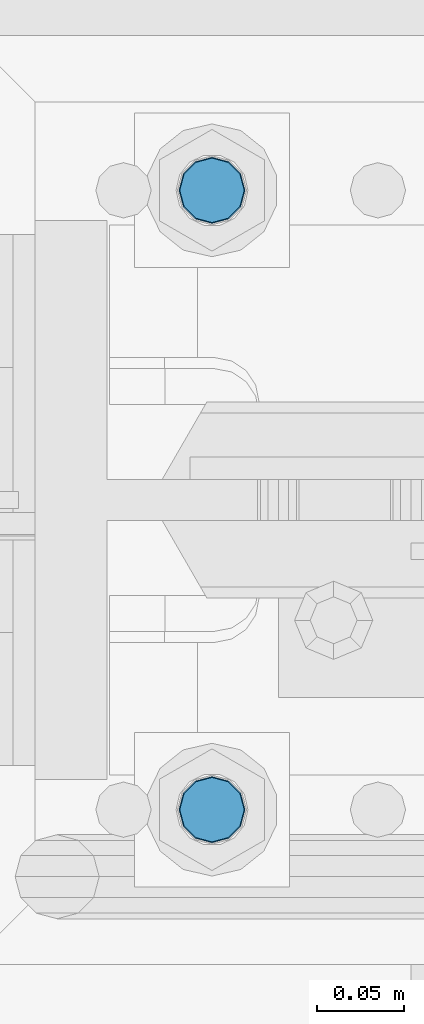
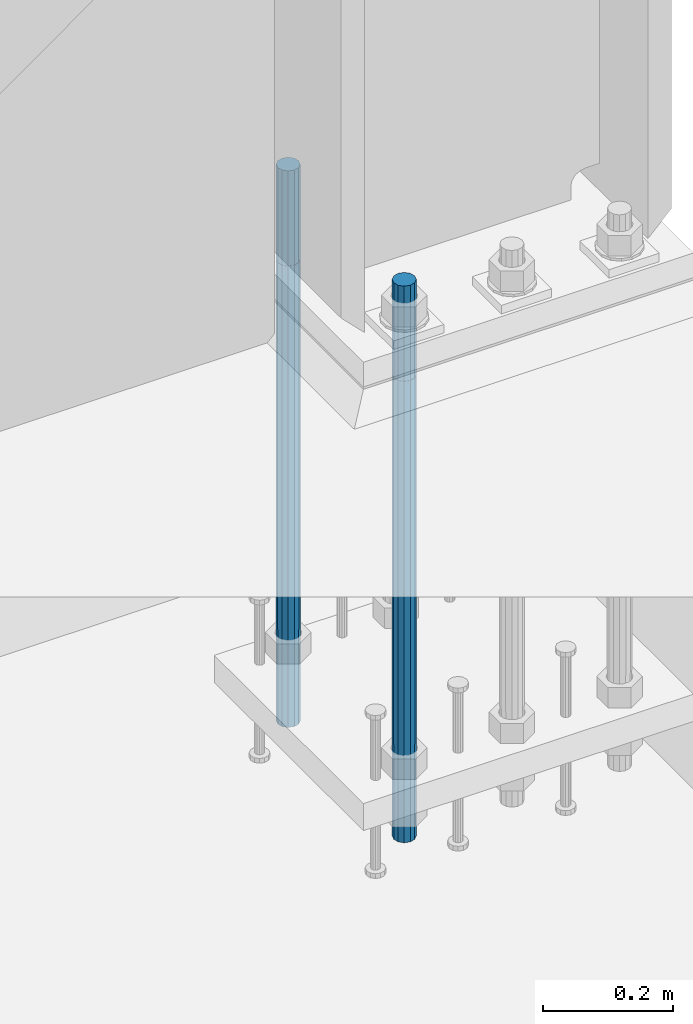
# One storey, part 752 of 1876: 2 columns, 1 element without a shape of its own.
"""IFC2X3 building model written with IfcOpenShell, lengths in millimetres."""

from ifc_helpers import new_model, si_unit, frame, origin_with_axes, place, context, subcontext, project, spatial, faceted_brep, material, type_object, element, aggregate, save


model = new_model("IFC2X3")

# Units and contexts
model_context = context("Model", 3, precision=1e-05, world=origin_with_axes())
body_context = subcontext(model_context, "Body", "Model", "MODEL_VIEW")
ifc_project = project(units=[si_unit("LENGTHUNIT", "METRE", prefix="MILLI"), si_unit("AREAUNIT", "SQUARE_METRE"), si_unit("VOLUMEUNIT", "CUBIC_METRE"), si_unit("MASSUNIT", "GRAM", prefix="KILO"), si_unit("TIMEUNIT", "SECOND"), si_unit("PLANEANGLEUNIT", "RADIAN"), si_unit("SOLIDANGLEUNIT", "STERADIAN"), si_unit("THERMODYNAMICTEMPERATUREUNIT", "DEGREE_CELSIUS"), si_unit("LUMINOUSINTENSITYUNIT", "LUMEN")], contexts=[model_context])

# Site, building, storey
site_placement = place(None, origin_with_axes())
site = spatial("IfcSite", under=ifc_project, at=site_placement, CompositionType="ELEMENT")
building_placement = place(site_placement, origin_with_axes())
building = spatial("IfcBuilding", under=site, at=building_placement, Name="Undefined", CompositionType="ELEMENT")
storey_placement = place(building_placement, origin_with_axes())
storey = spatial("IfcBuildingStorey", under=building, at=storey_placement, Name="Undefined", CompositionType="ELEMENT", Elevation=0.0)

# Assembly, columns
assembly_placement = place(storey_placement, origin_with_axes())
assembly = element("IfcElementAssembly", 1, at=assembly_placement, inside=storey, Name="TEMPLATE", AssemblyPlace="NOTDEFINED", PredefinedType="RIGID_FRAME")
ifc_material = material(Name="STEEL/F1554-GR.105")
column_type = type_object("IfcColumnType", PredefinedType="NOTDEFINED")
column_1_placement = place(assembly_placement, frame((7429.5, 13538.2, -1.4210854715202e-14), z_axis=(1.0, 0.0, 0.0), x_axis=(0.0, 0.0, -1.0)))
column_1 = element("IfcColumn", 2, at=column_1_placement, type_object=column_type, material=ifc_material, Name="ANCHOR_BOLTS", context=body_context, shape_type="Brep", body=[
    faceted_brep([(-177.8, -16.0214699700118, 9.25), (-177.8, -9.25, 16.0214699700121), (-177.8, 0.0, 18.5), (-177.8, 9.25, 16.0214699700121), (-177.8, 16.0214699700118, 9.25), (-177.8, 18.5, 0.0), (-177.8, 16.0214699700118, -9.25), (-177.8, 9.25, -16.0214699700121), (-177.8, 0.0, -18.5), (-177.8, -9.25, -16.0214699700121), (-177.8, -16.0214699700118, -9.25), (-177.8, -18.5, 0.0), (0.0, 18.5, 0.0), (0.0, 16.0214699700118, -9.25), (0.0, 9.25, -16.0214699700121), (0.0, 0.0, -18.5), (0.0, -9.25, -16.0214699700121), (0.0, -16.0214699700118, -9.25), (0.0, -18.5, 0.0), (0.0, -16.0214699700118, 9.25), (0.0, -9.25, 16.0214699700121), (0.0, 0.0, 18.5), (0.0, 9.25, 16.0214699700121), (0.0, 16.0214699700118, 9.25), (0.0, -16.4977839420935, 9.52500000000146), (0.0, -9.52500000000009, 16.4977839420935), (0.0, 0.0, 19.0499999999993), (0.0, 9.52500000000009, 16.4977839420935), (0.0, 16.4977839420935, 9.52500000000146), (-9.09494701772928e-13, 19.05, -1.81898940354586e-12), (0.0, 16.4977839420935, -9.52500000000146), (0.0, 9.52500000000009, -16.4977839420935), (0.0, 0.0, -19.05), (0.0, -9.52500000000009, -16.4977839420935), (0.0, -16.4977839420935, -9.52500000000146), (0.0, -19.0500000000002, 0.0), (685.799999999999, -19.05, 0.0), (685.799999999999, -16.4977839420936, 9.52500000000146), (685.799999999999, -9.52499999999998, 16.4977839420935), (685.799999999999, 0.0, 19.0499999999993), (685.799999999999, 9.52499999999998, 16.4977839420935), (685.799999999999, 16.4977839420936, 9.52500000000146), (685.799999999999, 19.05, 0.0), (685.799999999999, 16.4977839420936, -9.52500000000146), (685.799999999999, 9.52500000000003, -16.4977839420935), (685.799999999999, 0.0, -19.0499999999993), (685.799999999999, -9.52499999999998, -16.4977839420935), (685.799999999999, -16.4977839420936, -9.52500000000146), (685.8, -9.25, 16.0214699700121), (685.8, 0.0, 18.5), (685.8, 9.25, 16.0214699700121), (685.8, 16.0214699700118, 9.25), (685.8, 18.5, 0.0), (685.8, 16.0214699700118, -9.25), (685.8, 9.25, -16.0214699700121), (685.8, 0.0, -18.5), (685.8, -9.25, -16.0214699700121), (685.8, -16.0214699700118, -9.25), (685.8, -18.5, 0.0), (685.8, -16.0214699700118, 9.25), (863.6, -9.25, -16.0214699700121), (863.6, 0.0, -18.5), (863.6, 9.25, -16.0214699700121), (863.6, 16.0214699700118, -9.25), (863.6, 18.5, 0.0), (863.6, 16.0214699700118, 9.25), (863.6, 9.25, 16.0214699700121), (863.6, 0.0, 18.5), (863.6, -9.25, 16.0214699700121), (863.6, -16.0214699700118, 9.25), (863.6, -18.5, 0.0), (863.6, -16.0214699700118, -9.25)], [[[0, 1, 2, 3, 4, 5, 6, 7, 8, 9, 10, 11]], [[6, 5, 12, 13]], [[7, 6, 13, 14]], [[8, 7, 14, 15]], [[9, 8, 15, 16]], [[10, 9, 16, 17]], [[11, 10, 17, 18]], [[0, 11, 18, 19]], [[1, 0, 19, 20]], [[2, 1, 20, 21]], [[3, 2, 21, 22]], [[4, 3, 22, 23]], [[5, 4, 23, 12]], [[24, 25, 26, 27, 28, 29, 30, 31, 32, 33, 34, 35], [22, 21, 20, 19, 18, 17, 16, 15, 14, 13, 12, 23]], [[24, 35, 36, 37]], [[25, 24, 37, 38]], [[26, 25, 38, 39]], [[27, 26, 39, 40]], [[28, 27, 40, 41]], [[29, 28, 41, 42]], [[30, 29, 42, 43]], [[31, 30, 43, 44]], [[32, 31, 44, 45]], [[33, 32, 45, 46]], [[34, 33, 46, 47]], [[35, 34, 47, 36]], [[46, 45, 44, 43, 42, 41, 40, 39, 38, 37, 36, 47], [48, 49, 50, 51, 52, 53, 54, 55, 56, 57, 58, 59]], [[60, 61, 62, 63, 64, 65, 66, 67, 68, 69, 70, 71]], [[68, 67, 49, 48]], [[69, 68, 48, 59]], [[70, 69, 59, 58]], [[71, 70, 58, 57]], [[60, 71, 57, 56]], [[61, 60, 56, 55]], [[62, 61, 55, 54]], [[63, 62, 54, 53]], [[64, 63, 53, 52]], [[65, 64, 52, 51]], [[66, 65, 51, 50]], [[67, 66, 50, 49]]]),
])
column_2_placement = place(assembly_placement, frame((7429.5, 13893.8, -1.4210854715202e-14), z_axis=(-1.0, 0.0, 0.0), x_axis=(0.0, 0.0, -1.0)))
column_2 = element("IfcColumn", 3, at=column_2_placement, type_object=column_type, material=ifc_material, Name="ANCHOR_BOLTS", context=body_context, shape_type="Brep", body=[
    faceted_brep([(-177.8, -16.0214699700118, 9.25), (-177.8, -9.25, 16.0214699700121), (-177.8, 0.0, 18.5), (-177.8, 9.25, 16.0214699700121), (-177.8, 16.0214699700118, 9.25), (-177.8, 18.5, 0.0), (-177.8, 16.0214699700118, -9.25), (-177.8, 9.25, -16.0214699700121), (-177.8, 0.0, -18.5), (-177.8, -9.25, -16.0214699700121), (-177.8, -16.0214699700118, -9.25), (-177.8, -18.5, 0.0), (0.0, 18.5, 0.0), (0.0, 16.0214699700118, -9.25), (0.0, 9.25, -16.0214699700121), (0.0, 0.0, -18.5), (0.0, -9.25, -16.0214699700121), (0.0, -16.0214699700118, -9.25), (0.0, -18.5, 0.0), (0.0, -16.0214699700118, 9.25), (0.0, -9.25, 16.0214699700121), (0.0, 0.0, 18.5), (0.0, 9.25, 16.0214699700121), (0.0, 16.0214699700118, 9.25), (0.0, -16.4977839420935, 9.52500000000146), (0.0, -9.52500000000009, 16.4977839420935), (0.0, 0.0, 19.0499999999993), (0.0, 9.52500000000009, 16.4977839420935), (0.0, 16.4977839420935, 9.52500000000146), (-9.09494701772928e-13, 19.05, -1.81898940354586e-12), (0.0, 16.4977839420935, -9.52500000000146), (0.0, 9.52500000000009, -16.4977839420935), (0.0, 0.0, -19.05), (0.0, -9.52500000000009, -16.4977839420935), (0.0, -16.4977839420935, -9.52500000000146), (0.0, -19.0500000000002, 0.0), (685.799999999999, -19.05, 0.0), (685.799999999999, -16.4977839420936, 9.52500000000146), (685.799999999999, -9.52499999999998, 16.4977839420935), (685.799999999999, 0.0, 19.0499999999993), (685.799999999999, 9.52499999999998, 16.4977839420935), (685.799999999999, 16.4977839420936, 9.52500000000146), (685.799999999999, 19.05, 0.0), (685.799999999999, 16.4977839420936, -9.52500000000146), (685.799999999999, 9.52500000000003, -16.4977839420935), (685.799999999999, 0.0, -19.0499999999993), (685.799999999999, -9.52499999999998, -16.4977839420935), (685.799999999999, -16.4977839420936, -9.52500000000146), (685.8, -9.25, 16.0214699700121), (685.8, 0.0, 18.5), (685.8, 9.25, 16.0214699700121), (685.8, 16.0214699700118, 9.25), (685.8, 18.5, 0.0), (685.8, 16.0214699700118, -9.25), (685.8, 9.25, -16.0214699700121), (685.8, 0.0, -18.5), (685.8, -9.25, -16.0214699700121), (685.8, -16.0214699700118, -9.25), (685.8, -18.5, 0.0), (685.8, -16.0214699700118, 9.25), (863.6, -9.25, -16.0214699700121), (863.6, 0.0, -18.5), (863.6, 9.25, -16.0214699700121), (863.6, 16.0214699700118, -9.25), (863.6, 18.5, 0.0), (863.6, 16.0214699700118, 9.25), (863.6, 9.25, 16.0214699700121), (863.6, 0.0, 18.5), (863.6, -9.25, 16.0214699700121), (863.6, -16.0214699700118, 9.25), (863.6, -18.5, 0.0), (863.6, -16.0214699700118, -9.25)], [[[0, 1, 2, 3, 4, 5, 6, 7, 8, 9, 10, 11]], [[6, 5, 12, 13]], [[7, 6, 13, 14]], [[8, 7, 14, 15]], [[9, 8, 15, 16]], [[10, 9, 16, 17]], [[11, 10, 17, 18]], [[0, 11, 18, 19]], [[1, 0, 19, 20]], [[2, 1, 20, 21]], [[3, 2, 21, 22]], [[4, 3, 22, 23]], [[5, 4, 23, 12]], [[24, 25, 26, 27, 28, 29, 30, 31, 32, 33, 34, 35], [22, 21, 20, 19, 18, 17, 16, 15, 14, 13, 12, 23]], [[24, 35, 36, 37]], [[25, 24, 37, 38]], [[26, 25, 38, 39]], [[27, 26, 39, 40]], [[28, 27, 40, 41]], [[29, 28, 41, 42]], [[30, 29, 42, 43]], [[31, 30, 43, 44]], [[32, 31, 44, 45]], [[33, 32, 45, 46]], [[34, 33, 46, 47]], [[35, 34, 47, 36]], [[46, 45, 44, 43, 42, 41, 40, 39, 38, 37, 36, 47], [48, 49, 50, 51, 52, 53, 54, 55, 56, 57, 58, 59]], [[60, 61, 62, 63, 64, 65, 66, 67, 68, 69, 70, 71]], [[68, 67, 49, 48]], [[69, 68, 48, 59]], [[70, 69, 59, 58]], [[71, 70, 58, 57]], [[60, 71, 57, 56]], [[61, 60, 56, 55]], [[62, 61, 55, 54]], [[63, 62, 54, 53]], [[64, 63, 53, 52]], [[65, 64, 52, 51]], [[66, 65, 51, 50]], [[67, 66, 50, 49]]]),
])
aggregate(assembly, [column_1, column_2])

save(model, "model.ifc")
